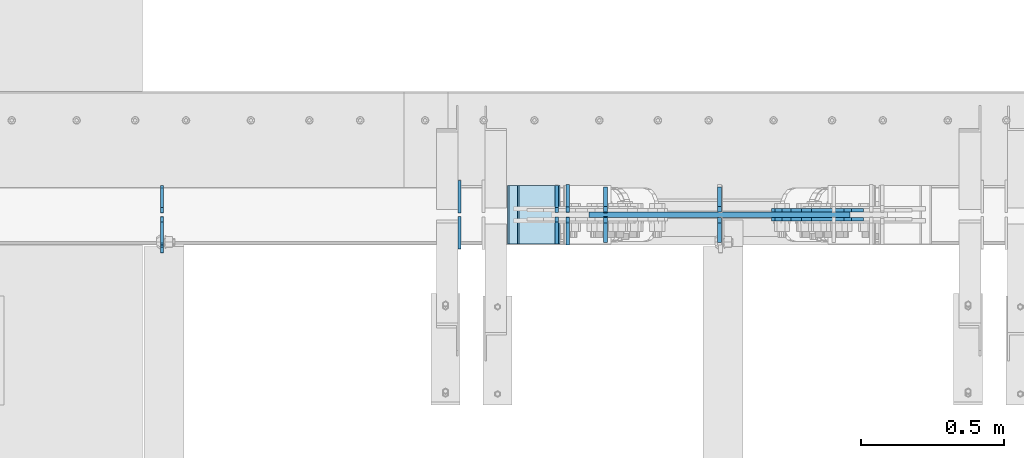
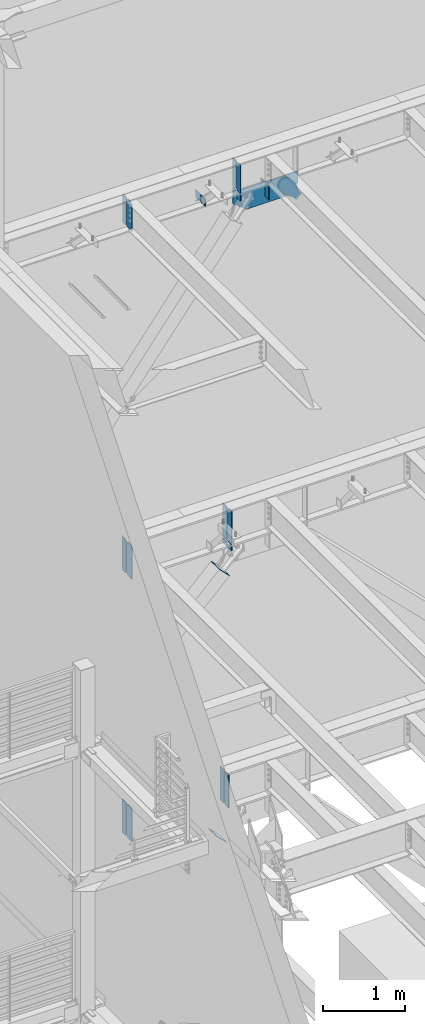
# One storey, part 1068 of 1179: 25 plates, 7 elements without a shape of their own.
"""IFC2X3 building model written with IfcOpenShell, lengths in millimetres."""

from ifc_helpers import new_model, si_unit, frame, origin_with_axes, place, context, subcontext, project, spatial, faceted_brep, material, type_object, element, aggregate, save


model = new_model("IFC2X3")

# Units and contexts
model_context = context("Model", 3, precision=1e-05, world=origin_with_axes())
body_context = subcontext(model_context, "Body", "Model", "MODEL_VIEW")
ifc_project = project(units=[si_unit("LENGTHUNIT", "METRE", prefix="MILLI"), si_unit("AREAUNIT", "SQUARE_METRE"), si_unit("VOLUMEUNIT", "CUBIC_METRE"), si_unit("MASSUNIT", "GRAM", prefix="KILO"), si_unit("TIMEUNIT", "SECOND"), si_unit("PLANEANGLEUNIT", "RADIAN"), si_unit("SOLIDANGLEUNIT", "STERADIAN"), si_unit("THERMODYNAMICTEMPERATUREUNIT", "DEGREE_CELSIUS"), si_unit("LUMINOUSINTENSITYUNIT", "LUMEN")], contexts=[model_context])

# Site, building, storey
site_placement = place(None, origin_with_axes())
site = spatial("IfcSite", under=ifc_project, at=site_placement, CompositionType="ELEMENT")
building_placement = place(site_placement, origin_with_axes())
building = spatial("IfcBuilding", under=site, at=building_placement, Name="Undefined", CompositionType="ELEMENT")
storey_placement = place(building_placement, origin_with_axes())
storey = spatial("IfcBuildingStorey", under=building, at=storey_placement, Name="Undefined", CompositionType="ELEMENT", Elevation=0.0)

# Assembly, plate
assembly_1_placement = place(storey_placement, origin_with_axes())
assembly_1 = element("IfcElementAssembly", 1, at=assembly_1_placement, inside=storey, Name="BEAM", AssemblyPlace="NOTDEFINED", PredefinedType="RIGID_FRAME")
ifc_material_1 = material(Name="STEEL/A36")
plate_type_1 = type_object("IfcPlateType", PredefinedType="NOTDEFINED")
plate_1_placement = place(assembly_1_placement, frame((2405.06200008392, 41193.24375, 12673.0125), z_axis=(0.0, 0.0, 1.0), x_axis=(0.0, -1.0, 0.0)))
plate_1 = element("IfcPlate", 2, at=plate_1_placement, type_object=plate_type_1, material=ifc_material_1, Name="PLATE", context=body_context, shape_type="Brep", body=[
    faceted_brep([(91.28125, -4.76250000000073, 425.450000000001), (91.28125, -4.76250000000073, 420.687499809264), (91.28125, 4.76250000000073, 420.687499809264), (91.28125, 4.76250000000073, 425.450000000001), (92.2479799225912, -4.76250000000073, 415.827420291219), (92.2479799225912, 4.76250000000073, 415.827420291219), (95.0009938230651, -4.76250000000073, 411.707243823065), (95.0009938230651, 4.76250000000073, 411.707243823065), (99.1211702912187, -4.76250000000073, 408.954229922587), (99.1211702912187, 4.76250000000073, 408.954229922587), (103.981249809265, -4.76250000000073, 407.987499999999), (103.981249809265, 4.76250000000073, 407.987499999999), (126.999999992826, -4.76249999999709, 407.9875), (127.0, 4.76249999999709, 407.9875), (0.0, -4.76249999999709, 406.400000762939), (19.0499992370605, -4.76249999999709, 425.45), (19.0499992370605, 4.76249999999709, 425.45), (0.0, 4.76249999999709, 406.400000762939), (0.0, -4.76250000000073, 19.0499992370605), (0.0, 4.76250000000073, 19.0499992370605), (19.0499992370605, -4.76250000000073, 0.0), (19.0499992370605, 4.76250000000073, 0.0), (127.0, -4.76250000000073, 0.0), (127.0, 4.76250000000073, 0.0)], [[[0, 1, 2, 3]], [[4, 5, 2, 1]], [[6, 7, 5, 4]], [[8, 9, 7, 6]], [[10, 11, 9, 8]], [[12, 13, 11, 10]], [[14, 15, 16, 17]], [[18, 14, 17, 19]], [[20, 18, 19, 21]], [[22, 20, 21, 23]], [[8, 6, 4, 1, 0, 15, 14, 18, 20, 22, 12, 10]], [[16, 15, 0, 3]], [[23, 21, 19, 17, 16, 3, 2, 5, 7, 9, 11, 13]], [[22, 23, 13, 12]]]),
])

assembly_2_placement = place(storey_placement, origin_with_axes())
assembly_2 = element("IfcElementAssembly", 3, at=assembly_2_placement, inside=storey, Name="BEAM", AssemblyPlace="NOTDEFINED", PredefinedType="RIGID_FRAME")
plate_2_placement = place(assembly_2_placement, frame((2405.06200008392, 41191.65625, 7489.825), z_axis=(0.0, 0.0, 1.0), x_axis=(0.0, -1.0, 0.0)))
plate_2 = element("IfcPlate", 4, at=plate_2_placement, type_object=plate_type_1, material=ifc_material_1, Name="PLATE", context=body_context, shape_type="Brep", body=[
    faceted_brep([(99.2187497618652, -4.76249999998072, 498.475), (99.21875, -4.76250000000073, 492.124999809264), (99.21875, 4.76250000000073, 492.124999809264), (99.2187499999927, 4.76250000001892, 498.475), (100.185479922588, -4.76250000000073, 487.264920291219), (100.185479922588, 4.76250000000073, 487.264920291219), (102.938493823065, -4.76250000000073, 483.144743823065), (102.938493823065, 4.76250000000073, 483.144743823065), (107.058670291219, -4.76250000000073, 480.391729922587), (107.058670291219, 4.76250000000073, 480.391729922587), (111.918749809265, -4.76250000000073, 479.424999999999), (111.918749809265, 4.76250000000073, 479.424999999999), (127.000007629395, -4.76250000000073, 479.424999999999), (127.000004683803, 4.76250000000073, 479.424999999999), (0.0, -4.76250000000073, 479.425006866455), (19.0499992370605, -4.76250000000073, 498.475006103516), (19.0499992370605, 4.76250000000073, 498.475006103516), (0.0, 4.76250000000073, 479.425006866455), (0.0, -4.76250000000073, 19.0499992370605), (0.0, 4.76250000000073, 19.0499992370605), (19.0499992370605, -4.76250000000073, 0.0), (19.0499992370605, 4.76250000000073, 0.0), (127.0, -4.76250000000073, 0.0), (127.0, 4.76250000000073, 0.0)], [[[0, 1, 2, 3]], [[4, 5, 2, 1]], [[6, 7, 5, 4]], [[8, 9, 7, 6]], [[10, 11, 9, 8]], [[12, 13, 11, 10]], [[14, 15, 16, 17]], [[18, 14, 17, 19]], [[20, 18, 19, 21]], [[22, 20, 21, 23]], [[8, 6, 4, 1, 0, 15, 14, 18, 20, 22, 12, 10]], [[16, 15, 0, 3]], [[23, 21, 19, 17, 16, 3, 2, 5, 7, 9, 11, 13]], [[22, 23, 13, 12]]]),
])

assembly_3_placement = place(storey_placement, origin_with_axes())
assembly_3 = element("IfcElementAssembly", 5, at=assembly_3_placement, inside=storey, Name="BEAM", AssemblyPlace="NOTDEFINED", PredefinedType="RIGID_FRAME")
plate_3_placement = place(assembly_3_placement, frame((2405.06176856844, 41191.6562498809, 3578.225), z_axis=(0.0, 0.0, 1.0), x_axis=(0.0, -1.0, 0.0)))
plate_3 = element("IfcPlate", 6, at=plate_3_placement, type_object=plate_type_1, material=ifc_material_1, Name="PLATE", context=body_context, shape_type="Brep", body=[
    faceted_brep([(100.185729626639, -4.76249977056068, 493.614920291231), (100.185729712364, 4.76250000001892, 493.614920291231), (99.2189997897731, 4.76250000002074, 498.475), (99.218999704055, -4.76249999998072, 498.475), (102.93874352712, -4.76249979533713, 489.494743823075), (102.938743612845, 4.76250000002074, 489.494743823075), (107.058919995281, -4.76249983241905, 486.741729922598), (107.058920081006, 4.76250000002074, 486.741729922598), (111.918999513335, -4.76249987616211, 485.775000000015), (111.918999599053, 4.76250000002074, 485.775000000015), (127.000004753965, -4.76249999997526, 485.775), (127.000004873044, 4.76250000002437, 485.775), (0.0, -4.76250000000073, 479.425006866455), (19.0499992370605, -4.76250000000073, 498.475006103516), (19.0499992370605, 4.76250000000073, 498.475006103516), (0.0, 4.76250000000073, 479.425006866455), (0.0, -4.76250000000073, 19.0499992370605), (0.0, 4.76250000000073, 19.0499992370605), (19.0499992370605, -4.76250000000073, 0.0), (19.0499992370605, 4.76250000000073, 0.0), (127.0, -4.76250000000073, 0.0), (127.0, 4.76250000000073, 0.0)], [[[0, 1, 2, 3]], [[4, 5, 1, 0]], [[6, 7, 5, 4]], [[8, 9, 7, 6]], [[10, 11, 9, 8]], [[12, 13, 14, 15]], [[16, 12, 15, 17]], [[18, 16, 17, 19]], [[20, 18, 19, 21]], [[6, 4, 0, 3, 13, 12, 16, 18, 20, 10, 8]], [[14, 13, 3, 2]], [[21, 19, 17, 15, 14, 2, 1, 5, 7, 9, 11]], [[20, 21, 11, 10]]]),
])

# Plate
plate_type_2 = type_object("IfcPlateType", PredefinedType="NOTDEFINED")
plate_4_placement = place(assembly_1_placement, frame((2405.0625, 41204.35625, 12673.0125), z_axis=(0.0, 0.0, 1.0), x_axis=(0.0, 1.0, 0.0)))
plate_4 = element("IfcPlate", 7, at=plate_4_placement, type_object=plate_type_2, material=ifc_material_1, Name="PLATE", context=body_context, shape_type="Brep", body=[
    faceted_brep([(0.0, -4.76250000000073, 19.0499992370605), (0.0, -4.76249999999709, 406.400000762939), (0.0, 4.76249999999709, 406.400000762939), (0.0, 4.76250000000073, 19.0499992370605), (19.0499992370605, -4.76249999999709, 425.45), (19.0499992370605, 4.76249999999709, 425.45), (88.9000015258789, -4.76250000000073, 425.450012207031), (88.9000015258789, 4.76250000000073, 425.450012207031), (88.8999999999996, -4.76250000000005, 0.0), (88.8999999999996, 4.76250000000005, 0.0), (19.0499992370605, -4.76250000000073, 0.0), (19.0499992370605, 4.76250000000073, 0.0)], [[[0, 1, 2, 3]], [[1, 4, 5, 2]], [[4, 6, 7, 5]], [[6, 8, 9, 7]], [[8, 10, 11, 9]], [[10, 0, 3, 11]], [[5, 7, 9, 11, 3, 2]], [[10, 8, 6, 4, 1, 0]]]),
])

ifc_material_2 = material(Name="STEEL/A572-GR.50")
plate_type_3 = type_object("IfcPlateType", PredefinedType="NOTDEFINED")
plate_5_placement = place(assembly_3_placement, frame((3786.6294582368, 41096.40625, 3578.225), z_axis=(0.0, 0.0, 1.0), x_axis=(0.0, 1.0, 0.0)))
plate_5 = element("IfcPlate", 8, at=plate_5_placement, type_object=plate_type_3, material=ifc_material_2, Name="PLATE", context=body_context, shape_type="Brep", body=[
    faceted_brep([(0.0, -6.34999999999854, 0.0), (0.0, -6.35000000019863, 498.474999998592), (0.0, 6.34999999979118, 498.474999998596), (0.0, 6.34999999999854, 0.0), (76.2000007629395, -6.35000000019863, 498.474999998592), (76.2000007629395, 6.34999999979118, 498.474999998596), (95.25, -6.350000000195, 479.425000761541), (95.25, 6.34999999980209, 479.425000761548), (95.25, -6.35000000000946, 19.0499992370496), (95.25, 6.34999999998399, 19.0499992370533), (76.2000007629395, -6.35000000000218, 0.0), (76.2000007629395, 6.34999999999491, 3.63797880709171e-12)], [[[0, 1, 2, 3]], [[1, 4, 5, 2]], [[4, 6, 7, 5]], [[6, 8, 9, 7]], [[8, 10, 11, 9]], [[10, 0, 3, 11]], [[5, 7, 9, 11, 3, 2]], [[10, 8, 6, 4, 1, 0]]]),
])

plate_6_placement = place(assembly_3_placement, frame((3786.6294582368, 41205.94375, 3578.225), z_axis=(0.0, 0.0, 1.0), x_axis=(0.0, 1.0, 0.0)))
plate_6 = element("IfcPlate", 9, at=plate_6_placement, type_object=plate_type_3, material=ifc_material_2, Name="PLATE", context=body_context, shape_type="Brep", body=[
    faceted_brep([(0.0, -6.35000000000036, 19.0499999999993), (0.0, -6.350000000195, 479.425000761541), (0.0, 6.34999999980209, 479.425000761548), (0.0, 6.35000000000036, 19.0499999999993), (19.0499992370605, -6.35000000019863, 498.474999998592), (19.0499992370605, 6.34999999979118, 498.474999998596), (95.25, -6.349999999793, 498.474999998598), (95.25, 6.35000000020045, 498.474999998592), (95.25, -6.34999999999309, 1.81898940354586e-12), (95.25, 6.34999999999854, -1.81898940354586e-12), (19.0500000000002, -6.35000000000036, 0.0), (19.0500000000002, 6.35000000000036, 0.0)], [[[0, 1, 2, 3]], [[1, 4, 5, 2]], [[4, 6, 7, 5]], [[6, 8, 9, 7]], [[8, 10, 11, 9]], [[3, 11, 10, 0]], [[5, 7, 9, 11, 3, 2]], [[10, 8, 6, 4, 1, 0]]]),
])

plate_type_4 = type_object("IfcPlateType", PredefinedType="NOTDEFINED")
plate_7_placement = place(assembly_2_placement, frame((3825.08124912137, 41205.94375, 7489.825), z_axis=(0.0, 1.0, 0.0), x_axis=(0.0, 0.0, 1.0)))
plate_7 = element("IfcPlate", 10, at=plate_7_placement, type_object=plate_type_4, material=ifc_material_2, Name="PLATE", context=body_context, shape_type="Brep", body=[
    faceted_brep([(0.0, -6.34999999998763, 17.4624996185248), (0.0, -6.35000000000036, 99.21875), (0.0, 6.35000000000036, 99.21875), (0.0, 6.35000000000582, 17.4624996185175), (498.475, -6.35000000000036, 99.21875), (498.475, 6.35000000000036, 99.21875), (498.474999999775, -6.34999999979482, 17.4624996185303), (498.474999999769, 6.35000000019681, 17.4624996185303), (481.012500381255, -6.34999999980209, 0.0), (481.01250038125, 6.35000000019136, 0.0), (17.4624996185303, -6.34999999999309, 1.81898940354586e-12), (17.4624996185303, 6.34999999999854, -1.81898940354586e-12)], [[[0, 1, 2, 3]], [[1, 4, 5, 2]], [[4, 6, 7, 5]], [[6, 8, 9, 7]], [[8, 10, 11, 9]], [[10, 0, 3, 11]], [[5, 7, 9, 11, 3, 2]], [[10, 8, 6, 4, 1, 0]]]),
])

plate_8_placement = place(assembly_2_placement, frame((3825.08124912137, 41191.65625, 7489.825), z_axis=(0.0, -1.0, 0.0), x_axis=(0.0, 0.0, 1.0)))
plate_8 = element("IfcPlate", 11, at=plate_8_placement, type_object=plate_type_4, material=ifc_material_2, Name="PLATE", context=body_context, shape_type="Brep", body=[
    faceted_brep([(0.0, -6.34999999998763, 17.4624996185248), (0.0, -6.35000000000036, 99.21875), (0.0, 6.35000000000036, 99.21875), (0.0, 6.35000000000582, 17.4624996185175), (498.475, -6.35000000000036, 99.21875), (498.475, 6.35000000000036, 99.21875), (498.474999999775, -6.34999999979482, 17.4624996185303), (498.474999999769, 6.35000000019681, 17.4624996185303), (481.012500381255, -6.34999999980209, 0.0), (481.01250038125, 6.35000000019136, 0.0), (17.4624996185303, -6.34999999999309, 1.81898940354586e-12), (17.4624996185303, 6.34999999999854, -1.81898940354586e-12)], [[[0, 1, 2, 3]], [[1, 4, 5, 2]], [[4, 6, 7, 5]], [[6, 8, 9, 7]], [[8, 10, 11, 9]], [[10, 0, 3, 11]], [[5, 7, 9, 11, 3, 2]], [[10, 8, 6, 4, 1, 0]]]),
])

plate_type_5 = type_object("IfcPlateType", PredefinedType="NOTDEFINED")
plate_9_placement = place(assembly_2_placement, frame((2405.0625, 41205.94375, 7489.825), z_axis=(0.0, 0.0, 1.0), x_axis=(0.0, 1.0, 0.0)))
plate_9 = element("IfcPlate", 12, at=plate_9_placement, type_object=plate_type_5, material=ifc_material_1, Name="PLATE", context=body_context, shape_type="Brep", body=[
    faceted_brep([(0.0, -4.76250000000073, 19.0499992370605), (0.0, -4.76250000000073, 479.425006866455), (0.0, 4.76250000000073, 479.425006866455), (0.0, 4.76250000000073, 19.0499992370605), (19.0499992370605, -4.76250000000073, 498.475006103516), (19.0499992370605, 4.76250000000073, 498.475006103516), (95.25, -4.76250000000073, 498.475006103516), (95.25, 4.76250000000073, 498.475006103516), (95.25, -4.76250000000073, 0.0), (95.25, 4.76250000000073, 0.0), (19.0499992370605, -4.76250000000073, 0.0), (19.0499992370605, 4.76250000000073, 0.0)], [[[0, 1, 2, 3]], [[1, 4, 5, 2]], [[4, 6, 7, 5]], [[6, 8, 9, 7]], [[8, 10, 11, 9]], [[10, 0, 3, 11]], [[5, 7, 9, 11, 3, 2]], [[10, 8, 6, 4, 1, 0]]]),
])

plate_10_placement = place(assembly_3_placement, frame((2405.06176854776, 41205.94375, 3578.225), z_axis=(0.0, 0.0, 1.0), x_axis=(0.0, 1.0, 0.0)))
plate_10 = element("IfcPlate", 13, at=plate_10_placement, type_object=plate_type_5, material=ifc_material_1, Name="PLATE", context=body_context, shape_type="Brep", body=[
    faceted_brep([(0.0, -4.76250000000073, 19.0499992370605), (0.0, -4.76250000000073, 479.425006866455), (0.0, 4.76250000000073, 479.425006866455), (0.0, 4.76250000000073, 19.0499992370605), (19.0499992370605, -4.76250000000073, 498.475006103516), (19.0499992370605, 4.76250000000073, 498.475006103516), (95.25, -4.76250000000073, 498.475006103516), (95.25, 4.76250000000073, 498.475006103516), (95.25, -4.76250000000073, 0.0), (95.25, 4.76250000000073, 0.0), (19.0499992370605, -4.76250000000073, 0.0), (19.0499992370605, 4.76250000000073, 0.0)], [[[0, 1, 2, 3]], [[1, 4, 5, 2]], [[4, 6, 7, 5]], [[6, 8, 9, 7]], [[8, 10, 11, 9]], [[10, 0, 3, 11]], [[5, 7, 9, 11, 3, 2]], [[10, 8, 6, 4, 1, 0]]]),
])

aggregate(assembly_3, [plate_5, plate_6, plate_10, plate_3])

# Assembly, plate
assembly_4_placement = place(storey_placement, origin_with_axes())
assembly_4 = element("IfcElementAssembly", 14, at=assembly_4_placement, inside=storey, Name="Plate", AssemblyPlace="NOTDEFINED", PredefinedType="RIGID_FRAME")
plate_type_6 = type_object("IfcPlateType", PredefinedType="NOTDEFINED")
plate_11_placement = place(assembly_4_placement, frame((3795.52033751597, 41097.2, 7036.84522484786), z_axis=(-0.705959813968941, 0.0, 0.708251890968841), x_axis=(0.0, 1.0, 0.0)))
plate_11 = element("IfcPlate", 15, at=plate_11_placement, type_object=plate_type_6, material=ifc_material_1, Name="Plate", context=body_context, shape_type="Brep", body=[
    faceted_brep([(0.0, -3.17500000000109, 0.0), (0.0, -3.17500000000291, 203.200000000368), (0.0, 3.17499999998836, 203.200000000361), (0.0, 3.17500000000109, 7.27595761418343e-12), (203.199999999997, -3.17500000000291, 203.200000000368), (203.199999999997, 3.17499999998836, 203.200000000361), (203.199999999997, -3.17499999999927, 3.63797880709171e-12), (203.199999999997, 3.17499999999382, -3.63797880709171e-12)], [[[0, 1, 2, 3]], [[1, 4, 5, 2]], [[4, 6, 7, 5]], [[6, 0, 3, 7]], [[5, 7, 3, 2]], [[6, 4, 1, 0]]]),
])
aggregate(assembly_4, [plate_11])

assembly_5_placement = place(storey_placement, origin_with_axes())
assembly_5 = element("IfcElementAssembly", 16, at=assembly_5_placement, inside=storey, Name="Plate", AssemblyPlace="NOTDEFINED", PredefinedType="RIGID_FRAME")
plate_12_placement = place(assembly_5_placement, frame((3762.92221357796, 41097.2, 3070.40776138544), z_axis=(-0.717593116036186, 0.0, 0.696462576035121), x_axis=(0.0, 1.0, 0.0)))
plate_12 = element("IfcPlate", 17, at=plate_12_placement, type_object=plate_type_6, material=ifc_material_1, Name="Plate", context=body_context, shape_type="Brep", body=[
    faceted_brep([(0.0, -3.17500000000109, 0.0), (0.0, -3.17500000000291, 203.200000000368), (0.0, 3.17499999998836, 203.200000000361), (0.0, 3.17500000000109, 7.27595761418343e-12), (203.199999999997, -3.17500000000291, 203.200000000368), (203.199999999997, 3.17499999998836, 203.200000000361), (203.199999999997, -3.17499999999927, 3.63797880709171e-12), (203.199999999997, 3.17499999999382, -3.63797880709171e-12)], [[[0, 1, 2, 3]], [[1, 4, 5, 2]], [[4, 6, 7, 5]], [[6, 0, 3, 7]], [[5, 7, 3, 2]], [[6, 4, 1, 0]]]),
])
aggregate(assembly_5, [plate_12])

# Plate
plate_type_7 = type_object("IfcPlateType", PredefinedType="NOTDEFINED")
plate_13_placement = place(assembly_1_placement, frame((3956.96833831038, 41208.325, 12652.3749999871), z_axis=(0.0, 1.0, 0.0), x_axis=(0.0, 0.0, -1.0)))
plate_13 = element("IfcPlate", 18, at=plate_13_placement, type_object=plate_type_7, material=ifc_material_2, Name="PLATE", context=body_context, shape_type="Brep", body=[
    faceted_brep([(0.0, 6.35000000000036, 19.0499999999993), (19.0500000000002, 6.35000000000036, 0.0), (19.0500000000002, -6.35000000000036, 0.0), (0.0, -6.35000000000036, 19.0499999999993), (0.0, -6.35000000000036, 87.3125), (0.0, 6.35000000000036, 87.3125), (92.4827269854632, -6.35000000000036, 87.3125), (92.4827269854632, 6.35000000000036, 87.3125), (92.4827269854632, -6.35000000000036, 0.0), (92.4827269854632, 6.35000000000036, 0.0)], [[[0, 1, 2, 3]], [[4, 5, 0, 3]], [[4, 6, 7, 5]], [[6, 8, 9, 7]], [[9, 8, 2, 1]], [[5, 7, 9, 1, 0]], [[8, 6, 4, 3, 2]]]),
])

plate_14_placement = place(assembly_1_placement, frame((3956.96833831038, 41189.275, 12652.3749999871), z_axis=(0.0, -1.0, 0.0), x_axis=(0.0, 0.0, -1.0)))
plate_14 = element("IfcPlate", 19, at=plate_14_placement, type_object=plate_type_7, material=ifc_material_2, Name="PLATE", context=body_context, shape_type="Brep", body=[
    faceted_brep([(0.0, 6.35000000000036, 19.0499999999993), (19.0500000000002, 6.35000000000036, 0.0), (19.0500000000002, -6.35000000000036, 0.0), (0.0, -6.35000000000036, 19.0499999999993), (0.0, -6.35000000000036, 87.3125), (0.0, 6.35000000000036, 87.3125), (92.4827269854632, -6.35000000000036, 87.3125), (92.4827269854632, 6.35000000000036, 87.3125), (92.4827269854632, -6.35000000000036, 0.0), (92.4827269854632, 6.35000000000036, 0.0)], [[[0, 1, 2, 3]], [[4, 5, 0, 3]], [[4, 6, 7, 5]], [[6, 8, 9, 7]], [[9, 8, 2, 1]], [[5, 7, 9, 1, 0]], [[8, 6, 4, 3, 2]]]),
])

plate_15_placement = place(assembly_1_placement, frame((4356.1, 41208.325, 12440.9078500253), z_axis=(0.0, 1.0, 0.0), x_axis=(0.0, 0.0, 1.0)))
plate_15 = element("IfcPlate", 20, at=plate_15_placement, type_object=plate_type_7, material=ifc_material_2, Name="PLATE", context=body_context, shape_type="Brep", body=[
    faceted_brep([(211.467149974746, -6.35000000000036, 19.0500000000029), (192.417149974746, -6.35000000000036, 0.0), (192.417149974746, 6.35000000000036, 0.0), (211.467149974746, 6.35000000000036, 19.0500000000029), (0.0, -6.34999999999854, 0.0), (0.0, -6.35000000000036, 87.3125), (0.0, 6.35000000000036, 87.3125), (0.0, 6.34999999999854, 0.0), (211.467149974746, -6.35000000000036, 87.3125), (211.467149974746, 6.35000000000036, 87.3125)], [[[0, 1, 2, 3]], [[4, 5, 6, 7]], [[5, 8, 9, 6]], [[9, 8, 0, 3]], [[4, 7, 2, 1]], [[7, 6, 9, 3, 2]], [[8, 5, 4, 1, 0]]]),
])

plate_16_placement = place(assembly_1_placement, frame((4356.1, 41189.275, 12440.9078500253), z_axis=(0.0, -1.0, 0.0), x_axis=(0.0, 0.0, 1.0)))
plate_16 = element("IfcPlate", 21, at=plate_16_placement, type_object=plate_type_7, material=ifc_material_2, Name="PLATE", context=body_context, shape_type="Brep", body=[
    faceted_brep([(211.467149974746, -6.35000000000036, 19.0500000000029), (192.417149974746, -6.35000000000036, 0.0), (192.417149974746, 6.35000000000036, 0.0), (211.467149974746, 6.35000000000036, 19.0500000000029), (0.0, -6.34999999999854, 0.0), (0.0, -6.35000000000036, 87.3125), (0.0, 6.35000000000036, 87.3125), (0.0, 6.34999999999854, 0.0), (211.467149974746, -6.35000000000036, 87.3125), (211.467149974746, 6.35000000000036, 87.3125)], [[[0, 1, 2, 3]], [[4, 5, 6, 7]], [[5, 8, 9, 6]], [[9, 8, 0, 3]], [[4, 7, 2, 1]], [[7, 6, 9, 3, 2]], [[8, 5, 4, 1, 0]]]),
])

plate_type_8 = type_object("IfcPlateType", PredefinedType="NOTDEFINED")
plate_17_placement = place(assembly_2_placement, frame((3825.08124912137, 41208.325, 7464.42500003379), z_axis=(0.0, 1.0, 0.0), x_axis=(0.0, 0.0, -1.0)))
plate_17 = element("IfcPlate", 22, at=plate_17_placement, type_object=plate_type_8, material=ifc_material_2, Name="PLATE", context=body_context, shape_type="Brep", body=[
    faceted_brep([(0.0, 6.35000000000036, 19.0499999999993), (19.0500000000002, 6.35000000000036, 0.0), (19.0500000000002, -6.35000000000036, 0.0), (0.0, -6.35000000000036, 19.0499999999993), (0.0, -6.35000000000036, 96.8374999999978), (0.0, 6.35000000000036, 96.8374999999978), (67.2703091782578, -6.34999999999991, 96.8375000000015), (67.2703091782578, 6.34999999999991, 96.8375000000015), (67.2703091782578, -6.34999999999991, 0.0), (67.2703091782578, 6.34999999999991, 0.0)], [[[0, 1, 2, 3]], [[4, 5, 0, 3]], [[4, 6, 7, 5]], [[6, 8, 9, 7]], [[9, 8, 2, 1]], [[5, 7, 9, 1, 0]], [[8, 6, 4, 3, 2]]]),
])

plate_18_placement = place(assembly_2_placement, frame((3825.08124912137, 41189.275, 7464.42500003379), z_axis=(0.0, -1.0, 0.0), x_axis=(0.0, 0.0, -1.0)))
plate_18 = element("IfcPlate", 23, at=plate_18_placement, type_object=plate_type_8, material=ifc_material_2, Name="PLATE", context=body_context, shape_type="Brep", body=[
    faceted_brep([(0.0, 6.35000000000036, 19.0499999999993), (19.0500000000002, 6.35000000000036, 0.0), (19.0500000000002, -6.35000000000036, 0.0), (0.0, -6.35000000000036, 19.0499999999993), (0.0, -6.35000000000036, 96.8374999999978), (0.0, 6.35000000000036, 96.8374999999978), (67.2703091782578, -6.34999999999991, 96.8375000000015), (67.2703091782578, 6.34999999999991, 96.8375000000015), (67.2703091782578, -6.34999999999991, 0.0), (67.2703091782578, 6.34999999999991, 0.0)], [[[0, 1, 2, 3]], [[4, 5, 0, 3]], [[4, 6, 7, 5]], [[6, 8, 9, 7]], [[9, 8, 2, 1]], [[5, 7, 9, 1, 0]], [[8, 6, 4, 3, 2]]]),
])

aggregate(assembly_2, [plate_17, plate_18, plate_7, plate_8, plate_9, plate_2])

plate_type_9 = type_object("IfcPlateType", PredefinedType="NOTDEFINED")
plate_19_placement = place(assembly_1_placement, frame((3956.94297237455, 41104.34375, 12673.0125), z_axis=(0.0, 0.0, 1.0), x_axis=(0.0, 1.0, 0.0)))
plate_19 = element("IfcPlate", 24, at=plate_19_placement, type_object=plate_type_9, material=ifc_material_2, Name="PLATE", context=body_context, shape_type="Brep", body=[
    faceted_brep([(0.0, -6.34999999999854, 0.0), (0.0, -6.34999999999991, 425.450012207031), (0.0, 6.34999999999991, 425.450012207031), (0.0, 6.34999999999854, 0.0), (69.8500022888184, -6.34999999999991, 425.450012207031), (69.8500022888184, 6.34999999999991, 425.450012207031), (88.9000015258789, -6.34999999999991, 406.400012969971), (88.9000015258789, 6.34999999999991, 406.400012969971), (88.9000015258789, -6.34999999999991, 19.0499992370605), (88.9000015258789, 6.34999999999991, 19.0499992370605), (69.849999425729, -6.34999999999854, 0.0), (69.849999425729, 6.34999999999854, 0.0)], [[[0, 1, 2, 3]], [[1, 4, 5, 2]], [[4, 6, 7, 5]], [[6, 8, 9, 7]], [[8, 10, 11, 9]], [[10, 0, 3, 11]], [[5, 7, 9, 11, 3, 2]], [[10, 8, 6, 4, 1, 0]]]),
])

plate_20_placement = place(assembly_1_placement, frame((3956.94297237455, 41204.35625, 12673.0125), z_axis=(0.0, 0.0, 1.0), x_axis=(0.0, 1.0, 0.0)))
plate_20 = element("IfcPlate", 25, at=plate_20_placement, type_object=plate_type_9, material=ifc_material_2, Name="PLATE", context=body_context, shape_type="Brep", body=[
    faceted_brep([(0.0, -6.35000000000036, 19.0499999999993), (0.0, -6.34999999999991, 406.400012969971), (0.0, 6.34999999999991, 406.400012969971), (0.0, 6.35000000000036, 19.0499999999993), (19.0499992370605, -6.34999999999991, 425.450012207031), (19.0499992370605, 6.34999999999991, 425.450012207031), (88.9000015258789, -6.34999999999991, 425.450012207031), (88.9000015258789, 6.34999999999991, 425.450012207031), (88.9000015258789, -6.34999999999991, 0.0), (88.9000015258789, 6.34999999999991, 0.0), (19.0500000000002, -6.35000000000036, 0.0), (19.0500000000002, 6.35000000000036, 0.0)], [[[0, 1, 2, 3]], [[1, 4, 5, 2]], [[4, 6, 7, 5]], [[6, 8, 9, 7]], [[8, 10, 11, 9]], [[3, 11, 10, 0]], [[5, 7, 9, 11, 3, 2]], [[10, 8, 6, 4, 1, 0]]]),
])

plate_type_10 = type_object("IfcPlateType", PredefinedType="NOTDEFINED")
plate_21_placement = place(assembly_1_placement, frame((3899.81833831038, 41198.8, 12483.6922717517), z_axis=(1.0, 0.0, 0.0), x_axis=(0.0, 0.0, 1.0)))
plate_21 = element("IfcPlate", 26, at=plate_21_placement, type_object=plate_type_10, material=ifc_material_2, Name="PLATE", context=body_context, shape_type="Brep", body=[
    faceted_brep([(0.0, -9.52499999999964, 0.0), (-144.384421726452, -9.52500000000146, 189.358533971189), (-144.384421726452, 9.52500000000146, 189.358533971189), (0.0, 9.52499999999964, 0.0), (-144.384421726452, -9.52500000000146, 462.631661689616), (-144.384421726452, 9.52500000000146, 462.631661689616), (-144.384421726452, -9.52500000000146, 723.204789414564), (-144.384421726452, 9.52500000000146, 723.204789414564), (6.07122274232097e-07, -9.52500000000146, 912.563324181986), (6.07122274232097e-07, 9.52500000000146, 912.563324181986), (168.682728248294, -9.52500000000146, 912.563324181985), (168.682728248294, 9.52500000000146, 912.563324181985), (168.682728248294, -9.52500000000146, -9.09494701772928e-13), (168.682728248294, 9.52500000000146, -9.09494701772928e-13)], [[[0, 1, 2, 3]], [[1, 4, 5, 2]], [[4, 6, 7, 5]], [[6, 8, 9, 7]], [[8, 10, 11, 9]], [[10, 12, 13, 11]], [[12, 0, 3, 13]], [[5, 7, 9, 11, 13, 3, 2]], [[12, 10, 8, 6, 4, 1, 0]]]),
])

# Assembly, plate
assembly_6_placement = place(storey_placement, origin_with_axes())
assembly_6 = element("IfcElementAssembly", 27, at=assembly_6_placement, inside=storey, AssemblyPlace="NOTDEFINED", PredefinedType="RIGID_FRAME")
plate_type_11 = type_object("IfcPlateType", PredefinedType="NOTDEFINED")
plate_22_placement = place(assembly_6_placement, frame((4817.93500631376, 41214.675, 12360.1610896218), z_axis=(-0.795206441873757, 0.0, -0.60633877890374), x_axis=(0.60633877890374, 0.0, -0.795206441873757)))
plate_22 = element("IfcPlate", 28, at=plate_22_placement, type_object=plate_type_11, material=ifc_material_1, context=body_context, shape_type="Brep", body=[
    faceted_brep([(0.0, -6.34999999999854, 0.0), (-101.600000000007, -6.34999999999854, -45.085691726028), (-101.600000000007, 6.34999999999854, -45.085691726028), (0.0, 6.34999999999854, 0.0), (-245.369242322517, -6.34999999999854, -45.085691725908), (-245.369242322517, 6.34999999999854, -45.085691725908), (-281.212328722571, -6.34999999999854, -37.9560585558283), (-281.212328722571, 6.34999999999854, -37.9560585558283), (-311.598630136563, -6.34999999999854, -17.6525810655148), (-311.598630136563, 6.34999999999854, -17.6525810655148), (-331.902107626699, -6.34999999999854, 12.7337203485949), (-331.902107626699, 6.34999999999854, 12.7337203485949), (-339.031740796561, -6.34999999999854, 48.5768098006738), (-339.031740796561, 6.34999999999854, 48.5768098006738), (-331.902107626408, -6.34999999999854, 84.4198962005139), (-331.902107626408, 6.34999999999854, 84.4198962005139), (-311.598630136172, -6.34999999999854, 114.806197614322), (-311.598630136172, 6.34999999999854, 114.806197614322), (-281.212328722244, -6.34999999999854, 135.109675104381), (-281.212328722244, 6.34999999999854, 135.109675104381), (-245.369240796288, -6.34999999999854, 142.239308274318), (-245.369240796288, 6.34999999999854, 142.239308274318), (-101.599999999052, -6.34999999999854, 142.239308274202), (-101.599999999052, 6.34999999999854, 142.239308274202), (4.938556230627e-10, -6.34999999999854, 97.1536165479993), (4.938556230627e-10, 6.34999999999854, 97.1536165479993), (68.5800000003655, -6.34999999999854, 97.153616547841), (68.5800000003655, 6.34999999999854, 97.153616547841), (68.5800000000518, -6.34999999999854, -9.09494701772928e-12), (68.5800000000518, 6.34999999999854, -9.09494701772928e-12)], [[[0, 1, 2, 3]], [[1, 4, 5, 2]], [[4, 6, 7, 5]], [[6, 8, 9, 7]], [[8, 10, 11, 9]], [[10, 12, 13, 11]], [[12, 14, 15, 13]], [[14, 16, 17, 15]], [[16, 18, 19, 17]], [[18, 20, 21, 19]], [[20, 22, 23, 21]], [[22, 24, 25, 23]], [[24, 26, 27, 25]], [[26, 28, 29, 27]], [[28, 0, 3, 29]], [[5, 7, 9, 11, 13, 15, 17, 19, 21, 23, 25, 27, 29, 3, 2]], [[28, 26, 24, 22, 20, 18, 16, 14, 12, 10, 8, 6, 4, 1, 0]]]),
])
aggregate(assembly_6, [plate_22])

assembly_7_placement = place(storey_placement, origin_with_axes())
assembly_7 = element("IfcElementAssembly", 29, at=assembly_7_placement, inside=storey, AssemblyPlace="NOTDEFINED", PredefinedType="RIGID_FRAME")
plate_23_placement = place(assembly_7_placement, frame((4817.93500631376, 41182.925, 12360.1610896218), z_axis=(-0.795206441873757, 0.0, -0.60633877890374), x_axis=(0.60633877890374, 0.0, -0.795206441873757)))
plate_23 = element("IfcPlate", 30, at=plate_23_placement, type_object=plate_type_11, material=ifc_material_1, context=body_context, shape_type="Brep", body=[
    faceted_brep([(0.0, -6.34999999999854, 0.0), (-101.600000000007, -6.34999999999854, -45.085691726028), (-101.600000000007, 6.34999999999854, -45.085691726028), (0.0, 6.34999999999854, 0.0), (-245.369242322517, -6.34999999999854, -45.085691725908), (-245.369242322517, 6.34999999999854, -45.085691725908), (-281.212328722571, -6.34999999999854, -37.9560585558283), (-281.212328722571, 6.34999999999854, -37.9560585558283), (-311.598630136563, -6.34999999999854, -17.6525810655148), (-311.598630136563, 6.34999999999854, -17.6525810655148), (-331.902107626699, -6.34999999999854, 12.7337203485949), (-331.902107626699, 6.34999999999854, 12.7337203485949), (-339.031740796561, -6.34999999999854, 48.5768098006738), (-339.031740796561, 6.34999999999854, 48.5768098006738), (-331.902107626408, -6.34999999999854, 84.4198962005139), (-331.902107626408, 6.34999999999854, 84.4198962005139), (-311.598630136172, -6.34999999999854, 114.806197614322), (-311.598630136172, 6.34999999999854, 114.806197614322), (-281.212328722244, -6.34999999999854, 135.109675104381), (-281.212328722244, 6.34999999999854, 135.109675104381), (-245.369240796288, -6.34999999999854, 142.239308274318), (-245.369240796288, 6.34999999999854, 142.239308274318), (-101.599999999052, -6.34999999999854, 142.239308274202), (-101.599999999052, 6.34999999999854, 142.239308274202), (4.938556230627e-10, -6.34999999999854, 97.1536165479993), (4.938556230627e-10, 6.34999999999854, 97.1536165479993), (68.5800000003655, -6.34999999999854, 97.153616547841), (68.5800000003655, 6.34999999999854, 97.153616547841), (68.5800000000518, -6.34999999999854, -9.09494701772928e-12), (68.5800000000518, 6.34999999999854, -9.09494701772928e-12)], [[[0, 1, 2, 3]], [[1, 4, 5, 2]], [[4, 6, 7, 5]], [[6, 8, 9, 7]], [[8, 10, 11, 9]], [[10, 12, 13, 11]], [[12, 14, 15, 13]], [[14, 16, 17, 15]], [[16, 18, 19, 17]], [[18, 20, 21, 19]], [[20, 22, 23, 21]], [[22, 24, 25, 23]], [[24, 26, 27, 25]], [[26, 28, 29, 27]], [[28, 0, 3, 29]], [[5, 7, 9, 11, 13, 15, 17, 19, 21, 23, 25, 27, 29, 3, 2]], [[28, 26, 24, 22, 20, 18, 16, 14, 12, 10, 8, 6, 4, 1, 0]]]),
])
aggregate(assembly_7, [plate_23])

# Plate
plate_type_12 = type_object("IfcPlateType", PredefinedType="NOTDEFINED")
plate_24_placement = place(assembly_1_placement, frame((3446.46250000001, 41193.24375, 12690.4749987075), z_axis=(0.0, -0.707106781186506, 0.707106781186589), x_axis=(0.0, -0.70710678118659, -0.707106781186505)))
plate_24 = element("IfcPlate", 31, at=plate_24_placement, type_object=plate_type_12, material=ifc_material_1, Name="PLATE", context=body_context, shape_type="Brep", body=[
    faceted_brep([(0.0, -4.76249999999709, 0.0), (-67.3519210815575, -4.76250000000073, 67.3519210815502), (-67.3519210815575, 4.76250000000073, 67.3519210815502), (0.0, 4.76249999999709, 0.0), (13.4703845975746, -4.76250000000073, 148.174224853334), (13.4703845975746, 4.76250000000073, 148.174224853334), (94.2926864622132, -4.76250000000073, 67.3519210813465), (94.2926864622132, 4.76250000000073, 67.3519210813465), (26.9407683631525, -4.76249999999709, -6.18456397205591e-11), (26.9407683631525, 4.76249999999709, -6.18456397205591e-11)], [[[0, 1, 2, 3]], [[1, 4, 5, 2]], [[4, 6, 7, 5]], [[6, 8, 9, 7]], [[8, 0, 3, 9]], [[5, 7, 9, 3, 2]], [[8, 6, 4, 1, 0]]]),
])

plate_25_placement = place(assembly_1_placement, frame((3446.46250000001, 41204.35625, 12690.4749987075), z_axis=(0.0, 0.707106781186542, 0.707106781186553), x_axis=(0.0, 0.707106781186553, -0.707106781186542)))
plate_25 = element("IfcPlate", 32, at=plate_25_placement, type_object=plate_type_12, material=ifc_material_1, Name="PLATE", context=body_context, shape_type="Brep", body=[
    faceted_brep([(0.0, -4.76249999999709, 0.0), (-67.3519210815575, -4.76250000000073, 67.3519210815502), (-67.3519210815575, 4.76250000000073, 67.3519210815502), (0.0, 4.76249999999709, 0.0), (13.4703845975746, -4.76250000000073, 148.174224853334), (13.4703845975746, 4.76250000000073, 148.174224853334), (94.2926864622132, -4.76250000000073, 67.3519210813465), (94.2926864622132, 4.76250000000073, 67.3519210813465), (26.9407683631525, -4.76249999999709, -6.18456397205591e-11), (26.9407683631525, 4.76249999999709, -6.18456397205591e-11)], [[[0, 1, 2, 3]], [[1, 4, 5, 2]], [[4, 6, 7, 5]], [[6, 8, 9, 7]], [[8, 0, 3, 9]], [[5, 7, 9, 3, 2]], [[8, 6, 4, 1, 0]]]),
])

aggregate(assembly_1, [plate_19, plate_20, plate_13, plate_14, plate_15, plate_16, plate_21, plate_24, plate_25, plate_4, plate_1])

save(model, "model.ifc")
